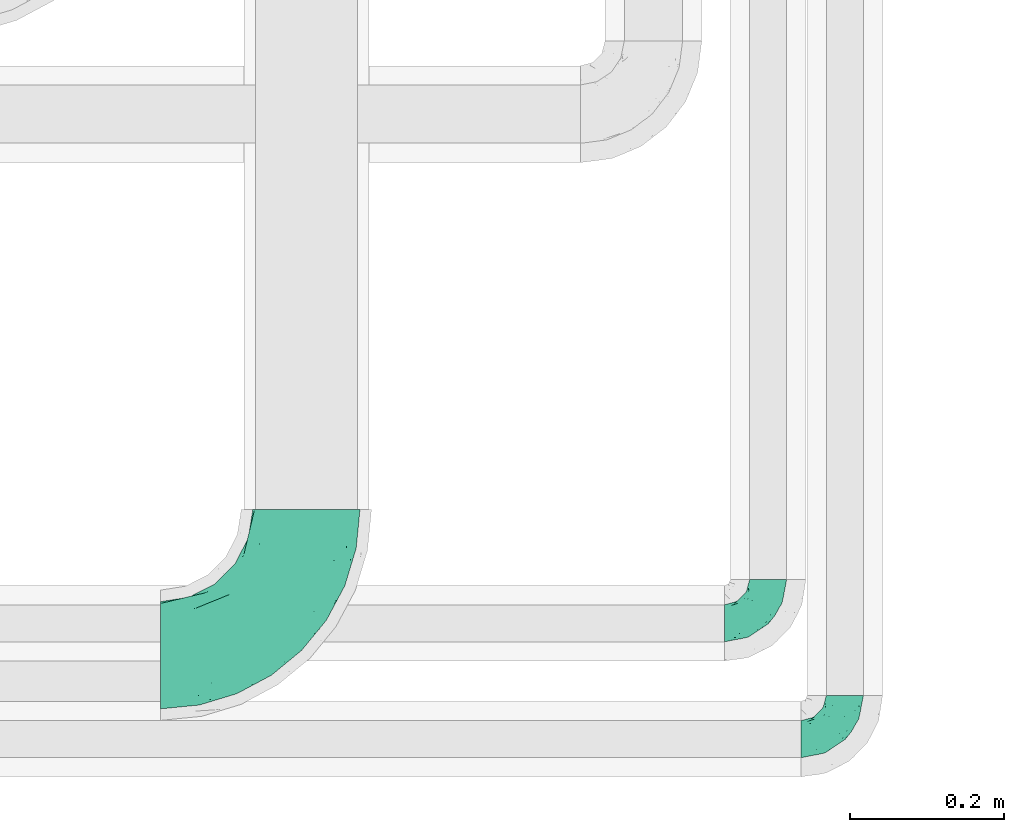
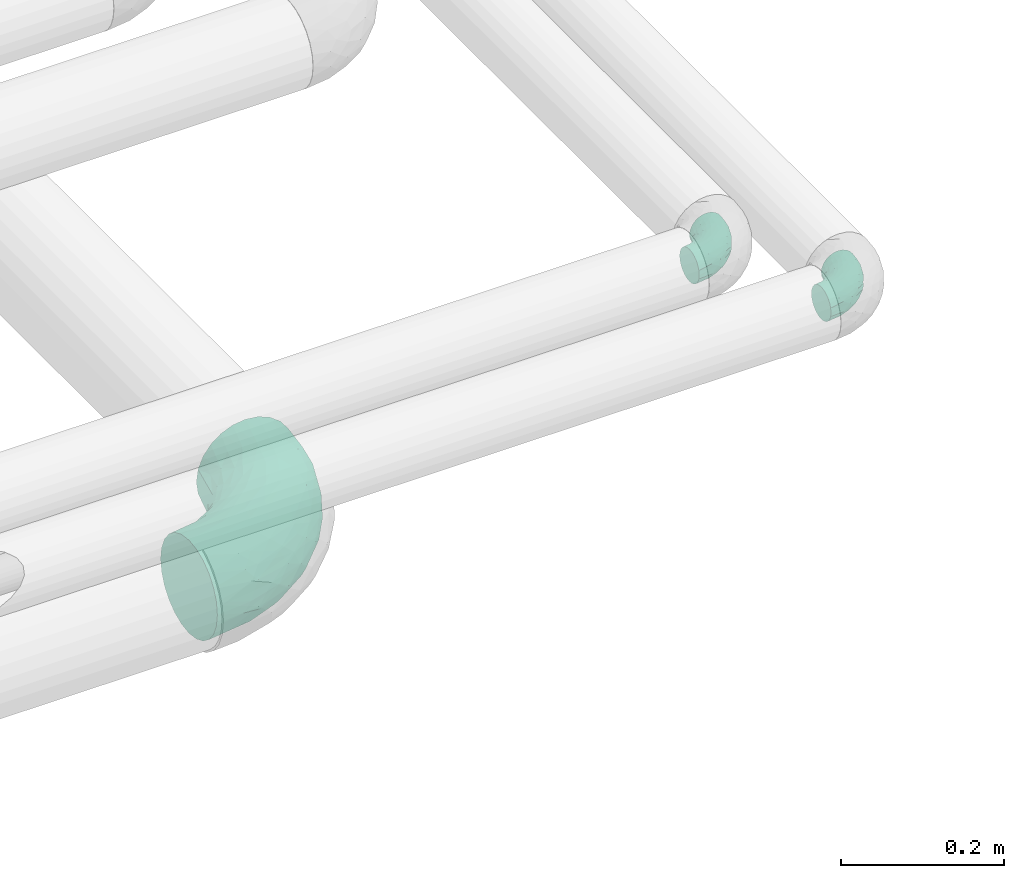
# One storey, part 722 of 827: 3 flow fittings.
"""IFC2X3 building model written with IfcOpenShell, lengths in millimetres."""

from ifc_helpers import new_model, entity, si_unit, converted_unit, derived_unit, direction, frame, origin, place, context, subcontext, project, spatial, faceted_brep, source, transform, mapped, material, type_object, type_shapes, element, save


model = new_model("IFC2X3")

# Units and contexts
model_context = context("Model", 3, precision=0.01, world=origin(), true_north=direction((6.12303176911189e-17, 1.0)))
body_context = subcontext(model_context, "Body", "Model", "MODEL_VIEW")
ifc_project = project(units=[si_unit("LENGTHUNIT", "METRE", prefix="MILLI"), si_unit("AREAUNIT", "SQUARE_METRE"), si_unit("VOLUMEUNIT", "CUBIC_METRE"), converted_unit("PLANEANGLEUNIT", "DEGREE", entity("IfcRatioMeasure", 0.0174532925199433), si_unit("PLANEANGLEUNIT", "RADIAN"), dimensions=[0, 0, 0, 0, 0, 0, 0]), si_unit("MASSUNIT", "GRAM", prefix="KILO"), derived_unit("MASSDENSITYUNIT", [(si_unit("MASSUNIT", "GRAM", prefix="KILO"), 1), (si_unit("LENGTHUNIT", "METRE"), -3)]), derived_unit("MOMENTOFINERTIAUNIT", [(si_unit("LENGTHUNIT", "METRE"), 4)]), si_unit("TIMEUNIT", "SECOND"), si_unit("FREQUENCYUNIT", "HERTZ"), si_unit("THERMODYNAMICTEMPERATUREUNIT", "DEGREE_CELSIUS"), derived_unit("THERMALTRANSMITTANCEUNIT", [(si_unit("MASSUNIT", "GRAM", prefix="KILO"), 1), (si_unit("THERMODYNAMICTEMPERATUREUNIT", "KELVIN"), -1), (si_unit("TIMEUNIT", "SECOND"), -3)]), derived_unit("VOLUMETRICFLOWRATEUNIT", [(si_unit("LENGTHUNIT", "METRE"), 3), (si_unit("TIMEUNIT", "SECOND"), -1)]), derived_unit("MASSFLOWRATEUNIT", [(si_unit("MASSUNIT", "GRAM", prefix="KILO"), 1), (si_unit("TIMEUNIT", "SECOND"), -1)]), derived_unit("ROTATIONALFREQUENCYUNIT", [(si_unit("TIMEUNIT", "SECOND"), -1)]), si_unit("ELECTRICCURRENTUNIT", "AMPERE"), si_unit("ELECTRICVOLTAGEUNIT", "VOLT"), si_unit("POWERUNIT", "WATT"), si_unit("FORCEUNIT", "NEWTON", prefix="KILO"), si_unit("ILLUMINANCEUNIT", "LUX"), si_unit("LUMINOUSFLUXUNIT", "LUMEN"), si_unit("LUMINOUSINTENSITYUNIT", "CANDELA"), derived_unit("USERDEFINED", [(si_unit("MASSUNIT", "GRAM", prefix="KILO"), -1), (si_unit("LENGTHUNIT", "METRE"), -2), (si_unit("TIMEUNIT", "SECOND"), 3), (si_unit("LUMINOUSFLUXUNIT", "LUMEN"), 1)]), derived_unit("LINEARVELOCITYUNIT", [(si_unit("LENGTHUNIT", "METRE"), 1), (si_unit("TIMEUNIT", "SECOND"), -1)]), si_unit("PRESSUREUNIT", "PASCAL"), derived_unit("USERDEFINED", [(si_unit("LENGTHUNIT", "METRE"), -2), (si_unit("MASSUNIT", "GRAM", prefix="KILO"), 1), (si_unit("TIMEUNIT", "SECOND"), -2)]), derived_unit("LINEARFORCEUNIT", [(si_unit("MASSUNIT", "GRAM", prefix="KILO"), 1), (si_unit("LENGTHUNIT", "METRE"), 1), (si_unit("TIMEUNIT", "SECOND"), -2), (si_unit("LENGTHUNIT", "METRE"), -1)]), derived_unit("PLANARFORCEUNIT", [(si_unit("MASSUNIT", "GRAM", prefix="KILO"), 1), (si_unit("LENGTHUNIT", "METRE"), 1), (si_unit("TIMEUNIT", "SECOND"), -2), (si_unit("LENGTHUNIT", "METRE"), -2)])], contexts=[model_context])

# Site, building, storey
site_placement = place(None, origin())
site = spatial("IfcSite", under=ifc_project, at=site_placement, CompositionType="ELEMENT")
building_placement = place(site_placement, origin())
building = spatial("IfcBuilding", under=site, at=building_placement, CompositionType="ELEMENT")
storey_placement = place(building_placement, frame((0.0, 0.0, 28200.0)))
storey = spatial("IfcBuildingStorey", under=building, at=storey_placement, Name="08", CompositionType="ELEMENT", Elevation=28200.0)

# Flow fittings
ifc_material = material()
pipe_fitting_type_1 = type_object("IfcPipeFittingType", Name="ADSK_1", PredefinedType="NOTDEFINED", material=ifc_material)
shared_shape_1 = source(origin(), body_context, "Body", "Brep", [
    faceted_brep([(-57.0, 12.07, -20.91), (-57.0, 6.25, -23.33), (-57.0, 0.0, -24.15), (-57.0, -6.25, -23.33), (-57.0, -12.08, -20.91), (-57.0, -17.08, -17.08), (-57.0, -20.91, -12.08), (-57.0, -23.33, -6.25), (-57.0, -24.15, 0.0), (-57.0, -23.33, 6.25), (-57.0, -20.91, 12.07), (-57.0, -17.08, 17.08), (-57.0, -12.08, 20.91), (-57.0, -6.25, 23.33), (-57.0, 0.0, 24.15), (-57.0, 6.25, 23.33), (-57.0, 12.07, 20.91), (-57.0, 17.08, 17.08), (-57.0, 20.91, 12.07), (-57.0, 23.33, 6.25), (-57.0, 24.15, 0.0), (-57.0, 23.33, -6.25), (-57.0, 20.91, -12.08), (-57.0, 17.08, -17.08), (0.0, 57.0, -24.15), (-6.25, 57.0, -23.33), (-12.07, 57.0, -20.91), (-17.08, 57.0, -17.08), (-20.91, 57.0, -12.08), (-23.33, 57.0, -6.25), (-24.15, 57.0, 0.0), (-23.33, 57.0, 6.25), (-20.91, 57.0, 12.07), (-17.08, 57.0, 17.08), (-12.07, 57.0, 20.91), (-6.25, 57.0, 23.33), (0.0, 57.0, 24.15), (6.25, 57.0, 23.33), (12.08, 57.0, 20.91), (17.08, 57.0, 17.08), (20.91, 57.0, 12.07), (23.33, 57.0, 6.25), (24.15, 57.0, 0.0), (23.33, 57.0, -6.25), (20.91, 57.0, -12.08), (17.08, 57.0, -17.08), (12.08, 57.0, -20.91), (6.25, 57.0, -23.33), (14.9, 21.14, 6.17), (13.61, 24.64, 12.48), (6.23, 8.95, 8.98), (-41.47, -21.06, 0.0), (-41.92, -18.38, 13.72), (-24.64, -13.61, 12.48), (-37.37, -13.24, 18.15), (-6.8, -4.93, 8.18), (-21.76, -15.19, 6.22), (-12.78, -9.18, 0.0), (-37.73, -20.51, 7.75), (-7.38, 7.38, 20.24), (-23.37, -4.26, 20.42), (-11.9, -3.19, 15.86), (-42.14, -8.7, 21.82), (13.24, 37.37, 18.15), (9.33, 23.53, 16.85), (4.26, 23.37, 20.42), (2.77, 10.92, 15.55), (-29.46, 0.91, 23.52), (-44.13, 20.56, 15.69), (-39.25, 26.33, 10.88), (-49.02, 22.92, 9.96), (-34.58, 23.87, 17.15), (-15.8, 6.8, 22.81), (-8.67, 20.47, 23.88), (-18.12, 12.9, 24.08), (-48.29, 14.92, 19.65), (-44.06, -2.85, 23.78), (-9.23, 48.95, 22.58), (-3.78, 42.74, 24.07), (-40.34, 4.26, 24.09), (-44.02, 26.14, 5.46), (-44.04, 9.88, 22.74), (-4.95, 16.87, 22.52), (-2.75, 1.43, 12.5), (-25.48, 40.98, 10.71), (20.51, 37.73, 7.75), (18.38, 41.92, 13.72), (8.7, 42.14, 21.82), (-25.95, -17.97, 0.0), (2.85, 44.06, 23.78), (21.06, 41.47, 0.0), (17.97, 25.95, 0.0), (-24.04, -9.27, 17.13), (-33.26, 33.26, 5.86), (-28.55, 40.57, 0.0), (-40.57, 28.55, 0.0), (-25.29, 47.19, 4.06), (-27.01, 31.1, 16.77), (-15.7, 43.95, 19.9), (-20.27, 45.22, 15.61), (-30.53, 31.98, 12.64), (-11.28, 38.33, 22.92), (-9.97, 27.88, 24.09), (-20.15, 30.26, 21.25), (-31.25, 11.75, 23.64), (-28.75, 7.23, 24.15), (-29.53, 18.06, 22.27), (-28.44, 24.21, 20.02), (-37.55, 17.7, 20.26), (-15.88, 29.25, 22.99), (-20.82, 20.82, 23.44), (-0.91, 29.46, 23.52), (-13.5, -7.67, 12.04), (1.49, 1.56, 5.16), (8.86, 10.35, 4.59), (0.38, -0.38, 0.0), (9.18, 12.78, 0.0), (-37.37, -13.24, -18.15), (8.86, 10.35, -4.59), (-45.22, 20.27, -15.61), (-43.95, 15.7, -19.9), (-38.33, 11.28, -22.92), (-48.95, 9.23, -22.58), (-47.19, 25.29, -4.06), (-33.26, 33.26, -5.86), (18.38, 41.92, -13.72), (-30.26, 20.15, -21.25), (2.85, 44.06, -23.78), (-4.26, 40.34, -24.09), (-40.98, 25.48, -10.71), (-41.92, -18.38, -13.72), (9.25, 23.5, -16.92), (4.26, 23.37, -20.42), (13.24, 37.37, -18.15), (-37.73, -20.51, -7.75), (-11.75, 31.25, -23.64), (-7.23, 28.75, -24.15), (-12.9, 18.12, -24.08), (8.7, 42.14, -21.82), (-44.06, -2.85, -23.78), (-6.8, 15.8, -22.81), (-20.47, 8.67, -23.88), (-24.64, -13.61, -12.48), (-42.74, 3.78, -24.07), (-18.06, 29.53, -22.27), (-24.21, 28.44, -20.02), (-27.88, 9.97, -24.09), (-31.1, 27.01, -16.77), (-26.14, 44.02, -5.46), (14.9, 21.14, -6.17), (20.51, 37.73, -7.75), (-9.88, 44.04, -22.74), (-20.56, 44.13, -15.69), (-21.76, -15.19, -6.22), (-13.5, -7.67, -12.04), (-24.14, -9.76, -16.74), (-11.9, -3.19, -15.86), (-14.92, 48.29, -19.65), (-23.37, -4.26, -20.42), (-0.91, 29.46, -23.52), (-26.33, 39.25, -10.88), (-23.87, 34.58, -17.15), (-42.14, -8.7, -21.82), (-22.92, 49.02, -9.96), (13.61, 24.64, -12.48), (-31.98, 30.53, -12.64), (-16.87, 4.95, -22.52), (-17.7, 37.55, -20.26), (-29.25, 15.88, -22.99), (-20.82, 20.82, -23.44), (-29.46, 0.91, -23.52), (-7.38, 7.38, -20.24), (2.77, 10.92, -15.55), (6.23, 8.95, -8.98), (-6.8, -4.93, -8.18), (-2.81, 1.41, -12.54), (1.49, 1.56, -5.16)], [[[0, 1, 2, 3, 4, 5, 6, 7, 8, 9, 10, 11, 12, 13, 14, 15, 16, 17, 18, 19, 20, 21, 22, 23]], [[24, 25, 26, 27, 28, 29, 30, 31, 32, 33, 34, 35, 36, 37, 38, 39, 40, 41, 42, 43, 44, 45, 46, 47]], [[48, 49, 50]], [[9, 8, 51]], [[52, 53, 54]], [[55, 56, 57]], [[10, 58, 52]], [[9, 58, 10]], [[59, 60, 61]], [[54, 12, 11]], [[54, 62, 12]], [[63, 39, 38]], [[64, 65, 66]], [[62, 60, 67]], [[68, 69, 70]], [[71, 69, 68]], [[72, 73, 74]], [[16, 75, 17]], [[13, 76, 14]], [[35, 77, 78]], [[14, 79, 15]], [[17, 68, 18]], [[14, 76, 79]], [[20, 19, 80]], [[70, 19, 18]], [[81, 15, 79]], [[15, 81, 16]], [[73, 72, 82]], [[66, 83, 50]], [[32, 31, 84]], [[85, 86, 49]], [[63, 87, 65]], [[56, 58, 88]], [[36, 89, 37]], [[85, 41, 40]], [[36, 35, 78]], [[90, 41, 85]], [[40, 39, 86]], [[12, 62, 13]], [[86, 85, 40]], [[48, 85, 49]], [[85, 91, 90]], [[87, 38, 37]], [[92, 60, 54]], [[80, 69, 93]], [[93, 94, 95]], [[10, 52, 11]], [[94, 96, 30]], [[97, 98, 99]], [[80, 93, 95]], [[100, 97, 84]], [[99, 98, 33]], [[101, 102, 78]], [[103, 101, 98]], [[96, 31, 30]], [[77, 98, 101]], [[77, 35, 34]], [[34, 33, 98]], [[9, 51, 58]], [[87, 63, 38]], [[104, 105, 74]], [[106, 103, 107]], [[106, 81, 104]], [[75, 68, 17]], [[108, 107, 71]], [[33, 32, 99]], [[109, 103, 110]], [[101, 109, 102]], [[89, 78, 111]], [[53, 52, 58]], [[54, 11, 52]], [[60, 62, 54]], [[88, 58, 51]], [[76, 62, 67]], [[53, 112, 92]], [[60, 59, 72]], [[39, 63, 86]], [[49, 86, 63]], [[89, 87, 37]], [[42, 41, 90]], [[111, 82, 65]], [[111, 65, 87]], [[65, 59, 66]], [[104, 81, 79]], [[75, 81, 108]], [[32, 84, 99]], [[97, 99, 84]], [[98, 97, 103]], [[106, 107, 108]], [[74, 102, 110]], [[111, 78, 102]], [[74, 110, 104]], [[74, 67, 72]], [[61, 92, 112]], [[66, 59, 61]], [[56, 53, 58]], [[66, 50, 49]], [[61, 112, 83]], [[66, 49, 64]], [[78, 89, 36]], [[87, 89, 111]], [[62, 76, 13]], [[79, 76, 67]], [[100, 93, 69]], [[96, 93, 84]], [[55, 113, 50]], [[113, 114, 50]], [[104, 79, 105]], [[106, 104, 110]], [[20, 80, 95]], [[85, 48, 91]], [[115, 114, 113]], [[116, 91, 48]], [[70, 80, 19]], [[93, 96, 94]], [[84, 31, 96]], [[103, 106, 110]], [[81, 106, 108]], [[103, 97, 107]], [[71, 107, 97]], [[71, 97, 100]], [[108, 71, 68]], [[79, 67, 105]], [[67, 74, 105]], [[115, 113, 57]], [[112, 56, 55]], [[56, 88, 57]], [[60, 72, 67]], [[82, 72, 59]], [[65, 82, 59]], [[82, 111, 73]], [[111, 102, 73]], [[102, 74, 73]], [[81, 75, 16]], [[68, 75, 108]], [[68, 70, 18]], [[80, 70, 69]], [[98, 77, 34]], [[78, 77, 101]], [[93, 100, 84]], [[71, 100, 69]], [[102, 109, 110]], [[101, 103, 109]], [[53, 92, 54]], [[61, 60, 92]], [[56, 112, 53]], [[83, 112, 55]], [[50, 83, 55]], [[61, 83, 66]], [[49, 63, 64]], [[65, 64, 63]], [[57, 113, 55]], [[114, 115, 116]], [[116, 48, 114]], [[48, 50, 114]], [[117, 5, 4]], [[116, 115, 118]], [[119, 120, 23]], [[121, 122, 120]], [[95, 123, 20]], [[0, 23, 120]], [[124, 95, 94]], [[125, 45, 44]], [[121, 120, 126]], [[24, 127, 128]], [[22, 21, 129]], [[0, 122, 1]], [[5, 117, 130]], [[131, 132, 133]], [[134, 88, 51]], [[135, 136, 137]], [[6, 5, 130]], [[46, 138, 47]], [[139, 3, 2]], [[140, 141, 137]], [[6, 134, 7]], [[134, 130, 142]], [[143, 2, 1]], [[144, 126, 145]], [[121, 146, 143]], [[147, 120, 119]], [[94, 148, 124]], [[149, 150, 91]], [[30, 29, 148]], [[151, 25, 128]], [[27, 152, 28]], [[134, 153, 88]], [[154, 155, 156]], [[27, 26, 157]], [[151, 26, 25]], [[155, 158, 156]], [[24, 47, 127]], [[1, 122, 143]], [[138, 132, 159]], [[160, 152, 161]], [[24, 128, 25]], [[46, 133, 138]], [[162, 117, 4]], [[148, 160, 124]], [[152, 160, 163]], [[154, 142, 155]], [[45, 125, 133]], [[133, 46, 45]], [[125, 164, 133]], [[51, 7, 134]], [[42, 90, 43]], [[165, 147, 129]], [[153, 134, 142]], [[43, 150, 44]], [[162, 4, 3]], [[141, 140, 166]], [[117, 162, 158]], [[163, 29, 28]], [[43, 90, 150]], [[123, 21, 20]], [[144, 151, 135]], [[157, 152, 27]], [[167, 145, 161]], [[23, 22, 119]], [[168, 126, 169]], [[121, 168, 146]], [[139, 143, 170]], [[142, 130, 117]], [[8, 7, 51]], [[134, 6, 130]], [[139, 162, 3]], [[170, 166, 158]], [[170, 158, 162]], [[158, 171, 156]], [[44, 150, 125]], [[91, 150, 90]], [[164, 125, 150]], [[132, 138, 133]], [[127, 138, 159]], [[131, 164, 172]], [[132, 171, 140]], [[135, 151, 128]], [[157, 151, 167]], [[22, 129, 119]], [[147, 119, 129]], [[120, 147, 126]], [[144, 145, 167]], [[137, 146, 169]], [[170, 143, 146]], [[137, 169, 135]], [[137, 159, 140]], [[171, 172, 156]], [[173, 174, 175]], [[156, 175, 154]], [[174, 57, 153]], [[132, 172, 171]], [[172, 164, 173]], [[143, 139, 2]], [[162, 139, 170]], [[138, 127, 47]], [[128, 127, 159]], [[165, 124, 160]], [[123, 124, 129]], [[149, 173, 164]], [[176, 174, 173]], [[135, 128, 136]], [[144, 135, 169]], [[150, 149, 164]], [[176, 118, 115]], [[149, 91, 116]], [[30, 148, 94]], [[163, 148, 29]], [[124, 123, 95]], [[129, 21, 123]], [[126, 144, 169]], [[151, 144, 167]], [[126, 147, 145]], [[161, 145, 147]], [[161, 147, 165]], [[167, 161, 152]], [[128, 159, 136]], [[159, 137, 136]], [[154, 153, 142]], [[132, 140, 159]], [[174, 176, 57]], [[57, 88, 153]], [[166, 140, 171]], [[158, 166, 171]], [[166, 170, 141]], [[170, 146, 141]], [[146, 137, 141]], [[151, 157, 26]], [[152, 157, 167]], [[152, 163, 28]], [[148, 163, 160]], [[120, 122, 0]], [[143, 122, 121]], [[124, 165, 129]], [[161, 165, 160]], [[146, 168, 169]], [[121, 126, 168]], [[142, 117, 155]], [[158, 155, 117]], [[175, 156, 172]], [[153, 154, 174]], [[173, 175, 172]], [[174, 154, 175]], [[164, 131, 133]], [[172, 132, 131]], [[176, 173, 118]], [[57, 176, 115]], [[173, 149, 118]], [[149, 116, 118]]]),
])
type_shapes(pipe_fitting_type_1, [shared_shape_1])
for number, where, name in (
    (1, (61052.64, 6416.57, 3100.0), "ADSK_1"),
    (2, (61152.64, 6265.71, 3100.0), "ADSK_1"),
):
    element("IfcFlowFitting", number, at=place(storey_placement, frame(where)), inside=storey, type_object=pipe_fitting_type_1, material=ifc_material, Name=name, ObjectType="ADSK_1", context=body_context, shape_type="MappedRepresentation", body=[
        mapped(shared_shape_1, transform((0.0, 0.0, 0.0), scale=1.0)),
    ])
pipe_fitting_type_2 = type_object("IfcPipeFittingType", Name="ADSK_1", PredefinedType="NOTDEFINED", material=ifc_material)
shared_shape_2 = source(origin(), body_context, "Body", "Brep", [
    faceted_brep([(-190.0, 18.08, -67.47), (-190.0, 0.0, -69.85), (-190.0, -18.08, -67.47), (-190.0, -34.93, -60.49), (-190.0, -49.39, -49.39), (-190.0, -60.49, -34.93), (-190.0, -67.47, -18.08), (-190.0, -69.85, 0.0), (-190.0, -67.47, 18.08), (-190.0, -60.49, 34.92), (-190.0, -49.39, 49.39), (-190.0, -34.93, 60.49), (-190.0, -18.08, 67.47), (-190.0, 0.0, 69.85), (-190.0, 18.08, 67.47), (-190.0, 34.92, 60.49), (-190.0, 49.39, 49.39), (-190.0, 60.49, 34.92), (-190.0, 67.47, 18.08), (-190.0, 69.85, 0.0), (-190.0, 67.47, -18.08), (-190.0, 60.49, -34.93), (-190.0, 49.39, -49.39), (-190.0, 34.92, -60.49), (18.08, 190.0, -67.47), (0.0, 190.0, -69.85), (-18.08, 190.0, -67.47), (-34.92, 190.0, -60.49), (-49.39, 190.0, -49.39), (-60.49, 190.0, -34.93), (-67.47, 190.0, -18.08), (-69.85, 190.0, 0.0), (-67.47, 190.0, 18.08), (-60.49, 190.0, 34.92), (-49.39, 190.0, 49.39), (-34.92, 190.0, 60.49), (-18.08, 190.0, 67.47), (0.0, 190.0, 69.85), (18.08, 190.0, 67.47), (34.93, 190.0, 60.49), (49.39, 190.0, 49.39), (60.49, 190.0, 34.92), (67.47, 190.0, 18.08), (69.85, 190.0, 0.0), (67.47, 190.0, -18.08), (60.49, 190.0, -34.93), (49.39, 190.0, -49.39), (34.93, 190.0, -60.49), (-29.62, 146.98, 65.62), (-13.75, 135.37, 69.64), (-124.22, -36.33, 52.83), (-140.23, -52.18, 40.04), (-80.56, -34.09, 36.78), (-140.97, -24.01, 63.29), (-80.93, -8.05, 59.8), (-100.59, 5.62, 68.24), (-125.19, -57.65, 22.9), (-139.31, -64.86, 0.0), (-28.7, -8.91, 22.6), (-45.64, -26.06, 0.0), (-6.26, 6.26, 0.0), (-105.44, 36.89, 68.2), (-118.83, 43.56, 64.34), (-146.98, 29.62, 65.62), (-71.47, -38.86, 17.07), (-90.56, -50.07, 0.0), (-0.6, 27.02, 35.97), (-44.76, -2.31, 47.74), (-42.86, -12.1, 35.78), (-148.03, -7.38, 68.85), (-135.37, 13.75, 69.64), (-67.48, 159.11, 28.79), (36.32, 124.15, 52.82), (-38.8, 102.11, 68.2), (-24.59, 96.61, 69.85), (-81.73, 130.22, 21.92), (-65.15, 30.31, 68.68), (-27.72, 54.52, 66.49), (-44.98, 61.25, 69.74), (-75.73, 152.87, 0.0), (-159.11, 67.48, 28.79), (-130.22, 81.73, 21.92), (-152.87, 75.73, 0.0), (-76.65, 126.59, 35.57), (-101.51, 101.51, 25.92), (-96.74, 96.74, 38.75), (-144.94, 60.97, 45.11), (-159.57, 43.91, 56.71), (-119.38, 92.8, 0.0), (50.07, 90.56, 0.0), (57.42, 124.25, 22.84), (38.8, 71.6, 17.49), (64.86, 139.31, 0.0), (52.17, 140.21, 40.03), (33.37, 79.39, 36.99), (24.0, 140.95, 63.29), (8.03, 80.92, 59.81), (-82.61, -22.17, 50.94), (7.38, 148.03, 68.85), (-100.26, 79.14, 51.33), (-75.76, 96.1, 55.72), (-76.12, 111.95, 46.7), (-92.8, 119.38, 0.0), (-104.27, 104.27, 12.31), (10.07, 27.17, 16.15), (26.06, 45.64, 0.0), (-61.21, 144.14, 45.16), (-44.13, 158.15, 56.77), (-55.26, 120.41, 58.38), (9.95, 57.03, 48.64), (29.48, 90.08, 47.56), (-5.62, 100.59, 68.24), (-122.78, 54.24, 58.28), (-86.25, 73.26, 61.12), (-95.79, 24.47, 69.85), (-126.59, 76.65, 35.57), (-17.15, 26.56, 50.85), (-29.82, 29.82, 59.54), (-70.73, 11.02, 65.19), (-58.6, 94.58, 64.16), (-71.14, 66.1, 67.41), (-158.15, 44.13, -56.77), (33.37, 79.39, -36.99), (10.07, 27.17, -16.15), (-0.6, 27.02, -35.97), (-100.59, 5.62, -68.24), (-148.03, -7.38, -68.85), (-135.37, 13.75, -69.64), (-130.22, 81.73, -21.92), (-146.98, 29.62, -65.62), (-102.11, 38.8, -68.2), (-96.61, 24.59, -69.85), (-83.02, -24.86, -48.76), (-44.76, -2.31, -47.74), (-80.56, -34.09, -36.78), (-122.68, -57.24, -22.15), (-71.43, -38.87, -16.95), (-104.27, 104.27, -12.31), (-159.11, 67.48, -28.79), (-144.14, 61.21, -45.16), (7.38, 148.03, -68.85), (-13.75, 135.37, -69.64), (-79.14, 100.26, -51.33), (-96.1, 75.76, -55.72), (-111.95, 76.12, -46.7), (-80.93, -8.05, -59.8), (-124.22, -36.33, -52.83), (-140.23, -52.18, -40.04), (-24.47, 95.79, -69.85), (-36.89, 105.44, -68.2), (-150.18, -65.36, -13.92), (-43.56, 118.83, -64.34), (-29.62, 146.98, -65.62), (38.8, 71.6, -17.49), (-81.73, 130.22, -21.92), (-28.7, -8.91, -22.6), (-54.24, 122.78, -58.28), (-73.26, 86.25, -61.12), (-61.25, 44.98, -69.74), (-30.31, 65.15, -68.68), (-54.52, 27.72, -66.49), (-101.51, 101.51, -25.92), (-126.59, 76.65, -35.57), (-96.74, 96.74, -38.75), (-67.48, 159.11, -28.79), (-120.41, 55.26, -58.38), (-43.91, 159.57, -56.71), (24.0, 140.95, -63.29), (8.03, 80.92, -59.81), (-5.62, 100.59, -68.24), (-60.97, 144.94, -45.11), (36.32, 124.15, -52.82), (57.42, 124.25, -22.84), (52.17, 140.21, -40.03), (-140.97, -24.01, -63.29), (9.95, 57.03, -48.64), (-76.65, 126.59, -35.57), (22.84, 89.04, -52.94), (-11.03, 70.74, -65.2), (-29.82, 29.82, -59.54), (-94.58, 58.6, -64.16), (-66.1, 71.14, -67.41), (-31.42, -3.01, -36.09), (-13.88, 24.32, -46.86)], [[[0, 1, 2, 3, 4, 5, 6, 7, 8, 9, 10, 11, 12, 13, 14, 15, 16, 17, 18, 19, 20, 21, 22, 23]], [[24, 25, 26, 27, 28, 29, 30, 31, 32, 33, 34, 35, 36, 37, 38, 39, 40, 41, 42, 43, 44, 45, 46, 47]], [[36, 48, 49]], [[50, 51, 52]], [[53, 54, 55]], [[56, 9, 8]], [[8, 7, 57]], [[58, 59, 60]], [[51, 9, 56]], [[61, 62, 63]], [[59, 58, 64]], [[59, 64, 65]], [[11, 10, 50]], [[66, 67, 68]], [[50, 53, 11]], [[69, 70, 13]], [[71, 33, 32]], [[72, 40, 39]], [[73, 74, 49]], [[63, 15, 14]], [[13, 70, 14]], [[71, 32, 75]], [[12, 69, 13]], [[76, 77, 78]], [[32, 79, 75]], [[18, 80, 81]], [[63, 14, 70]], [[82, 19, 18]], [[83, 84, 85]], [[86, 16, 87]], [[82, 81, 88]], [[82, 18, 81]], [[15, 87, 16]], [[83, 71, 75]], [[52, 56, 64]], [[49, 37, 36]], [[89, 90, 91]], [[36, 35, 48]], [[42, 41, 90]], [[89, 92, 90]], [[11, 53, 12]], [[73, 78, 74]], [[65, 56, 57]], [[40, 72, 93]], [[94, 90, 93]], [[41, 40, 93]], [[72, 95, 96]], [[95, 39, 38]], [[8, 57, 56]], [[43, 42, 92]], [[67, 54, 97]], [[38, 37, 98]], [[99, 100, 101]], [[102, 75, 79]], [[51, 10, 9]], [[102, 88, 103]], [[31, 79, 32]], [[104, 60, 105]], [[106, 34, 33]], [[84, 103, 81]], [[91, 105, 89]], [[107, 35, 34]], [[106, 108, 107]], [[49, 48, 73]], [[104, 105, 91]], [[16, 86, 17]], [[58, 104, 66]], [[109, 110, 96]], [[111, 98, 49]], [[112, 113, 99]], [[92, 42, 90]], [[95, 72, 39]], [[70, 114, 61]], [[80, 18, 17]], [[101, 106, 83]], [[99, 86, 112]], [[115, 81, 80]], [[90, 94, 91]], [[94, 66, 104]], [[64, 58, 68]], [[56, 65, 64]], [[93, 72, 110]], [[90, 41, 93]], [[98, 95, 38]], [[111, 77, 96]], [[111, 96, 95]], [[67, 116, 117]], [[52, 51, 56]], [[50, 10, 51]], [[54, 53, 50]], [[69, 53, 55]], [[97, 52, 67]], [[118, 76, 55]], [[107, 48, 35]], [[73, 119, 120]], [[61, 63, 70]], [[63, 62, 87]], [[94, 104, 91]], [[58, 60, 104]], [[109, 66, 94]], [[67, 117, 54]], [[68, 67, 52]], [[116, 66, 109]], [[119, 48, 108]], [[73, 120, 78]], [[120, 61, 114]], [[78, 114, 76]], [[49, 98, 37]], [[95, 98, 111]], [[53, 69, 12]], [[70, 69, 55]], [[70, 55, 114]], [[120, 113, 62]], [[76, 114, 55]], [[120, 114, 78]], [[118, 55, 54]], [[76, 118, 77]], [[96, 77, 117]], [[111, 78, 77]], [[54, 117, 118]], [[77, 118, 117]], [[110, 109, 94]], [[116, 96, 117]], [[106, 107, 34]], [[48, 107, 108]], [[75, 84, 83]], [[106, 33, 71]], [[101, 83, 85]], [[106, 71, 83]], [[99, 101, 85]], [[108, 106, 101]], [[99, 85, 115]], [[113, 112, 62]], [[119, 113, 120]], [[100, 99, 113]], [[17, 86, 80]], [[115, 85, 84]], [[80, 86, 115]], [[99, 115, 86]], [[63, 87, 15]], [[86, 87, 112]], [[78, 111, 74]], [[111, 49, 74]], [[119, 100, 113]], [[101, 100, 108]], [[48, 119, 73]], [[119, 108, 100]], [[75, 102, 103]], [[115, 84, 81]], [[81, 103, 88]], [[75, 103, 84]], [[54, 50, 97]], [[52, 97, 50]], [[64, 68, 52]], [[66, 68, 58]], [[62, 61, 120]], [[87, 62, 112]], [[93, 110, 94]], [[96, 110, 72]], [[66, 116, 67]], [[96, 116, 109]], [[22, 121, 23]], [[122, 123, 124]], [[125, 126, 127]], [[20, 82, 128]], [[129, 130, 127]], [[130, 131, 127]], [[19, 82, 20]], [[132, 133, 134]], [[88, 128, 82]], [[135, 136, 65]], [[102, 137, 88]], [[138, 20, 128]], [[139, 22, 21]], [[140, 141, 25]], [[142, 143, 144]], [[145, 133, 132]], [[4, 146, 147]], [[141, 148, 149]], [[7, 6, 150]], [[138, 21, 20]], [[5, 4, 147]], [[149, 151, 152]], [[59, 65, 136]], [[122, 153, 123]], [[79, 30, 154]], [[134, 155, 136]], [[150, 65, 57]], [[156, 157, 142]], [[126, 2, 1]], [[134, 135, 147]], [[130, 158, 131]], [[159, 160, 158]], [[154, 161, 137]], [[0, 23, 129]], [[127, 1, 0]], [[162, 138, 128]], [[161, 163, 162]], [[30, 79, 31]], [[146, 4, 3]], [[154, 30, 164]], [[152, 27, 26]], [[165, 121, 139]], [[25, 24, 140]], [[25, 141, 26]], [[164, 30, 29]], [[27, 166, 28]], [[167, 168, 169]], [[141, 152, 26]], [[28, 170, 29]], [[47, 171, 167]], [[172, 89, 153]], [[59, 155, 60]], [[28, 166, 170]], [[46, 45, 173]], [[153, 89, 105]], [[105, 123, 153]], [[174, 146, 3]], [[171, 47, 46]], [[45, 44, 172]], [[7, 150, 57]], [[43, 92, 44]], [[122, 124, 175]], [[89, 172, 92]], [[171, 173, 122]], [[47, 167, 24]], [[173, 171, 46]], [[135, 150, 5]], [[0, 129, 127]], [[174, 3, 2]], [[79, 154, 102]], [[146, 174, 145]], [[44, 92, 172]], [[144, 139, 162]], [[142, 170, 156]], [[176, 154, 164]], [[105, 60, 123]], [[122, 172, 153]], [[45, 172, 173]], [[122, 173, 172]], [[167, 171, 177]], [[140, 167, 169]], [[177, 122, 175]], [[178, 159, 169]], [[134, 136, 135]], [[155, 59, 136]], [[134, 147, 146]], [[135, 5, 147]], [[126, 174, 2]], [[125, 160, 145]], [[125, 145, 174]], [[145, 179, 133]], [[121, 129, 23]], [[130, 180, 181]], [[149, 152, 141]], [[152, 151, 166]], [[60, 155, 123]], [[123, 155, 124]], [[182, 134, 133]], [[175, 179, 168]], [[183, 179, 175]], [[155, 182, 124]], [[180, 129, 165]], [[130, 181, 158]], [[181, 149, 148]], [[158, 148, 159]], [[127, 126, 1]], [[174, 126, 125]], [[167, 140, 24]], [[141, 140, 169]], [[141, 169, 148]], [[181, 157, 151]], [[159, 148, 169]], [[181, 148, 158]], [[178, 169, 168]], [[159, 178, 160]], [[145, 160, 179]], [[125, 158, 160]], [[168, 179, 178]], [[160, 178, 179]], [[175, 124, 183]], [[177, 175, 168]], [[139, 121, 22]], [[129, 121, 165]], [[128, 161, 162]], [[139, 21, 138]], [[144, 162, 163]], [[139, 138, 162]], [[142, 144, 163]], [[165, 139, 144]], [[142, 163, 176]], [[157, 156, 151]], [[180, 157, 181]], [[143, 142, 157]], [[29, 170, 164]], [[176, 163, 161]], [[164, 170, 176]], [[142, 176, 170]], [[152, 166, 27]], [[170, 166, 156]], [[158, 125, 131]], [[125, 127, 131]], [[180, 143, 157]], [[144, 143, 165]], [[129, 180, 130]], [[180, 165, 143]], [[128, 88, 137]], [[176, 161, 154]], [[154, 137, 102]], [[128, 137, 161]], [[5, 150, 6]], [[65, 150, 135]], [[134, 146, 132]], [[145, 132, 146]], [[134, 182, 155]], [[183, 182, 133]], [[151, 149, 181]], [[166, 151, 156]], [[182, 183, 124]], [[179, 183, 133]], [[167, 177, 168]], [[122, 177, 171]]]),
])
type_shapes(pipe_fitting_type_2, [shared_shape_2])
flow_fitting_placement = place(storey_placement, frame((60451.05, 6375.0, 2900.0)))
element("IfcFlowFitting", 3, at=flow_fitting_placement, inside=storey, type_object=pipe_fitting_type_2, material=ifc_material, Name="ADSK_1", ObjectType="ADSK_1", context=body_context, shape_type="MappedRepresentation", body=[
    mapped(shared_shape_2, transform((0.0, 0.0, 0.0), scale=1.0)),
])

save(model, "model.ifc")
